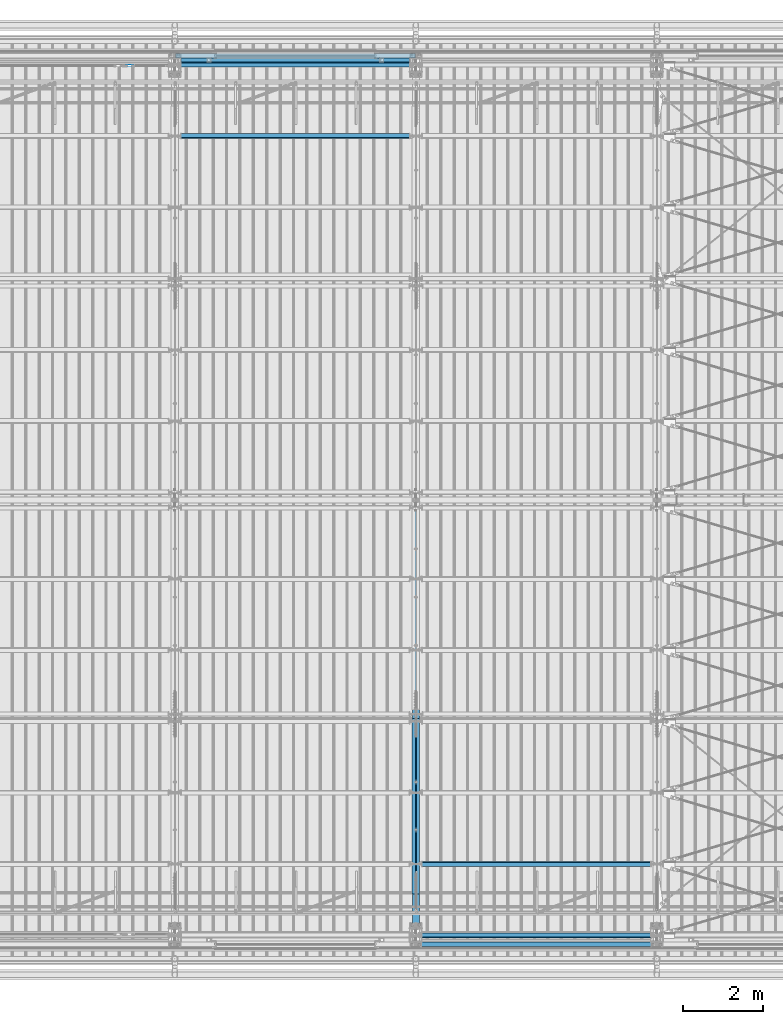
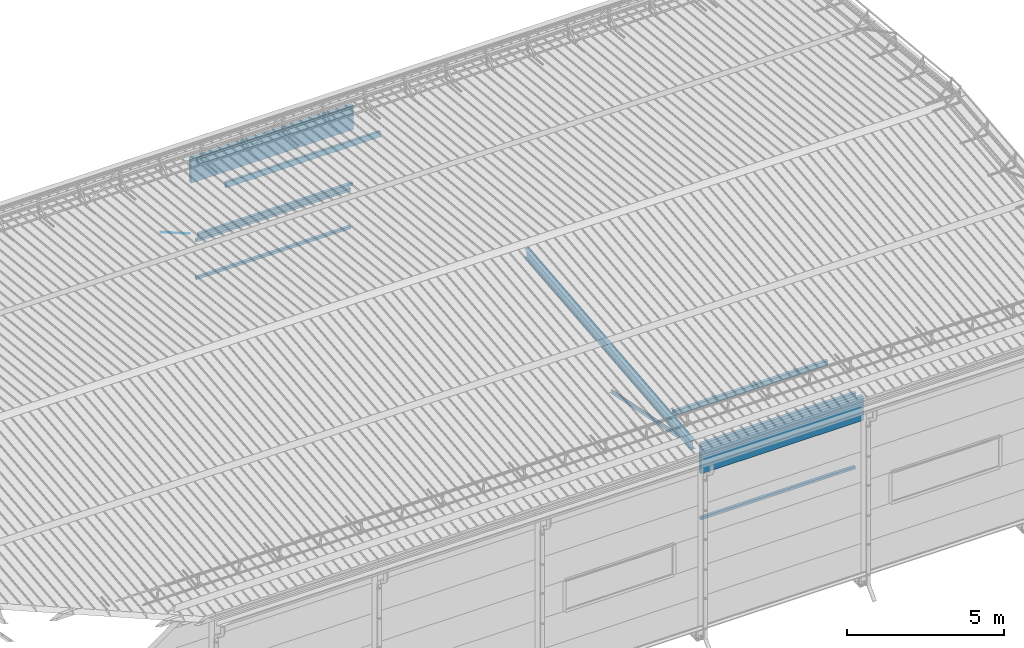
# One storey, part 271 of 709: 13 beams, 1 member, 1 opening, 14 elements without a shape of their own.
"""IFC4 building model written with IfcOpenShell, lengths in millimetres."""

from ifc_helpers import new_model, si_unit, direction, frame, origin_with_axes, place, context, subcontext, project, spatial, line, indexed_curve, outline, extrude, polygons, material, element, aggregate, save


model = new_model("IFC4")

# Units and contexts
model_context = context("Model", 3, precision=0.2, world=origin_with_axes(), true_north=direction((0.0, 1.0)))
body_context = subcontext(model_context, "Body", "Model", "MODEL_VIEW")
reference_context = subcontext(model_context, "Reference", "Model", "MODEL_VIEW")
ifc_project = project(units=[si_unit("LENGTHUNIT", "METRE", prefix="MILLI"), si_unit("AREAUNIT", "SQUARE_METRE"), si_unit("VOLUMEUNIT", "CUBIC_METRE"), si_unit("MASSUNIT", "GRAM", prefix="KILO"), si_unit("TIMEUNIT", "SECOND"), si_unit("PLANEANGLEUNIT", "RADIAN"), si_unit("SOLIDANGLEUNIT", "STERADIAN"), si_unit("THERMODYNAMICTEMPERATUREUNIT", "DEGREE_CELSIUS"), si_unit("LUMINOUSINTENSITYUNIT", "LUMEN")], contexts=[model_context])

# Site, building, storey
site_placement = place(None, origin_with_axes())
site = spatial("IfcSite", under=ifc_project, at=site_placement, CompositionType="ELEMENT")
building_placement = place(site_placement, origin_with_axes())
building = spatial("IfcBuilding", under=site, at=building_placement, Name="Undefined", CompositionType="ELEMENT")
storey_placement = place(building_placement, origin_with_axes())
storey = spatial("IfcBuildingStorey", under=building, at=storey_placement, Name="Undefined", CompositionType="ELEMENT", Elevation=0.0)

# Assembly, beam
assembly_1_placement = place(storey_placement, frame((34000.0, 346.0, 7089.70002), z_axis=(1.0, 0.0, 0.0), x_axis=(0.0, 0.9950371902, 0.099503719)))
assembly_1 = element("IfcElementAssembly", 1, at=assembly_1_placement, inside=storey)
ifc_material_1 = material(Name="C355-5", Category="STEEL")
beam_1_placement = place(assembly_1_placement, origin_with_axes())
beam_1 = element("IfcBeam", 2, at=beam_1_placement, material=ifc_material_1, ObjectType="432", context=body_context, shape_type="Tessellation", body=[
    polygons([(3.80474, -173.0, -87.0), (4.70474, -164.0, -87.0), (10665.6128, -164.0, -87.0), (10664.7128, -173.0, -87.0), (4.70474, -164.0, -3.0), (10665.6128, -164.0, -3.0), (37.50474, 164.0, -3.0), (10698.4128, 164.0, -3.0), (37.50474, 164.0, -87.0), (10698.4128, 164.0, -87.0), (38.40474, 173.0, -87.0), (10699.3128, 173.0, -87.0), (38.40474, 173.0, 87.0), (10699.3128, 173.0, 87.0), (37.50474, 164.0, 87.0), (10698.4128, 164.0, 87.0), (37.50474, 164.0, 3.0), (10698.4128, 164.0, 3.0), (4.70474, -164.0, 3.0), (10665.6128, -164.0, 3.0), (4.70474, -164.0, 87.0), (10665.6128, -164.0, 87.0), (3.80474, -173.0, 87.0), (10664.7128, -173.0, 87.0)], [[[1, 2, 3, 4]], [[2, 5, 6, 3]], [[5, 7, 8, 6]], [[7, 9, 10, 8]], [[9, 11, 12, 10]], [[11, 13, 14, 12]], [[13, 15, 16, 14]], [[15, 17, 18, 16]], [[17, 19, 20, 18]], [[19, 21, 22, 20]], [[21, 23, 24, 22]], [[23, 1, 4, 24]], [[6, 8, 10, 12, 14, 16, 18, 20, 22, 24, 4, 3]], [[23, 21, 19, 17, 15, 13, 11, 9, 7, 5, 2, 1]]], closed=True),
])
aggregate(assembly_1, [beam_1])

assembly_2_placement = place(storey_placement, frame((33949.0, 350.0596, 7109.99804), z_axis=(0.0, 0.1961161349, 0.9805806757), x_axis=(0.0, 0.9805806757, -0.1961161349)))
assembly_2 = element("IfcElementAssembly", 3, at=assembly_2_placement, inside=storey)
ifc_material_2 = material(Name="C345-5", Category="STEEL")
beam_2_placement = place(assembly_2_placement, origin_with_axes())
beam_2 = element("IfcBeam", 4, at=beam_2_placement, material=ifc_material_2, ObjectType="444", context=body_context, shape_type="Tessellation", body=[
    polygons([(868.11437, -45.0, -45.0), (868.11437, 45.0, -45.0), (5317.375, 45.0, -45.0), (5317.375, -45.0, -45.0), (868.11437, 45.0, -39.0), (5317.375, 45.0, -39.0), (868.11437, -39.0, -39.0), (5317.375, -39.0, -39.0), (868.11437, -39.0, 45.0), (5317.375, -39.0, 45.0), (868.11437, -45.0, 45.0), (5317.375, -45.0, 45.0)], [[[1, 2, 3, 4]], [[2, 5, 6, 3]], [[5, 7, 8, 6]], [[7, 9, 10, 8]], [[9, 11, 12, 10]], [[11, 1, 4, 12]], [[6, 8, 10, 12, 4, 3]], [[11, 9, 7, 5, 2, 1]]], closed=True),
])
aggregate(assembly_2, [beam_2])

assembly_3_placement = place(storey_placement, frame((34051.0, 5677.0596, 6044.59804), z_axis=(0.0, 0.1961161349, 0.9805806757), x_axis=(0.0, -0.9805806757, 0.1961161349)))
assembly_3 = element("IfcElementAssembly", 5, at=assembly_3_placement, inside=storey)
beam_3_placement = place(assembly_3_placement, origin_with_axes())
beam_3 = element("IfcBeam", 6, at=beam_3_placement, material=ifc_material_2, ObjectType="444", context=body_context, shape_type="Tessellation", body=[
    polygons([(115.12039, -45.0, -45.0), (115.12039, 45.0, -45.0), (4564.38102, 45.0, -45.0), (4564.38102, -45.0, -45.0), (115.12039, 45.0, -39.0), (4564.38102, 45.0, -39.0), (115.12039, -39.0, -39.0), (4564.38102, -39.0, -39.0), (115.12039, -39.0, 45.0), (4564.38102, -39.0, 45.0), (115.12039, -45.0, 45.0), (4564.38102, -45.0, 45.0)], [[[1, 2, 3, 4]], [[2, 5, 6, 3]], [[5, 7, 8, 6]], [[7, 9, 10, 8]], [[9, 11, 12, 10]], [[11, 1, 4, 12]], [[6, 8, 10, 12, 4, 3]], [[11, 9, 7, 5, 2, 1]]], closed=True),
])
aggregate(assembly_3, [beam_3])

assembly_4_placement = place(storey_placement, frame((34000.0, 173.0, 4310.0), z_axis=(0.0, 0.0, -1.0), x_axis=(1.0, 0.0, 0.0)))
assembly_4 = element("IfcElementAssembly", 7, at=assembly_4_placement, inside=storey)
ifc_material_3 = material(Name="C355", Category="STEEL")
beam_4_placement = place(assembly_4_placement, origin_with_axes())
beam_4 = element("IfcBeam", 8, at=beam_4_placement, material=ifc_material_3, ObjectType="546", context=body_context, shape_type="Tessellation", body=[
    polygons([(155.0, -47.0, -47.0), (155.0, -47.0, 47.0), (5845.0, -47.0, 47.0), (5845.0, -47.0, -47.0), (155.0, 47.0, 47.0), (5845.0, 47.0, 47.0), (155.0, 47.0, -47.0), (5845.0, 47.0, -47.0), (155.0, -50.0, -50.0), (155.0, 50.0, -50.0), (5845.0, 50.0, -50.0), (5845.0, -50.0, -50.0), (155.0, 50.0, 50.0), (5845.0, 50.0, 50.0), (155.0, -50.0, 50.0), (5845.0, -50.0, 50.0)], [[[1, 2, 3, 4]], [[2, 5, 6, 3]], [[5, 7, 8, 6]], [[7, 1, 4, 8]], [[9, 10, 11, 12]], [[10, 13, 14, 11]], [[13, 15, 16, 14]], [[15, 9, 12, 16]], [[14, 16, 12, 11], [6, 8, 4, 3]], [[15, 13, 10, 9], [7, 5, 2, 1]]], closed=True),
])
aggregate(assembly_4, [beam_4])

assembly_5_placement = place(storey_placement, frame((34000.0, 21950.0, 2550.0), z_axis=(0.0, 0.0, -1.0), x_axis=(-1.0, 0.0, 0.0)))
assembly_5 = element("IfcElementAssembly", 9, at=assembly_5_placement, inside=storey)
beam_5_placement = place(assembly_5_placement, origin_with_axes())
beam_5 = element("IfcBeam", 10, at=beam_5_placement, material=ifc_material_3, ObjectType="545", context=body_context, shape_type="Tessellation", body=[
    polygons([(155.0, -47.0, -47.0), (155.0, -47.0, 47.0), (5845.0, -47.0, 47.0), (5845.0, -47.0, -47.0), (155.0, 47.0, 47.0), (5845.0, 47.0, 47.0), (155.0, 47.0, -47.0), (5845.0, 47.0, -47.0), (155.0, -50.0, -50.0), (155.0, 50.0, -50.0), (5845.0, 50.0, -50.0), (5845.0, -50.0, -50.0), (155.0, 50.0, 50.0), (5845.0, 50.0, 50.0), (155.0, -50.0, 50.0), (5845.0, -50.0, 50.0)], [[[1, 2, 3, 4]], [[2, 5, 6, 3]], [[5, 7, 8, 6]], [[7, 1, 4, 8]], [[9, 10, 11, 12]], [[10, 13, 14, 11]], [[13, 15, 16, 14]], [[15, 9, 12, 16]], [[14, 16, 12, 11], [6, 8, 4, 3]], [[15, 13, 10, 9], [7, 5, 2, 1]]], closed=True),
])
aggregate(assembly_5, [beam_5])

assembly_6_placement = place(storey_placement, frame((34000.0, 21950.0, 4020.0), z_axis=(0.0, 0.0, -1.0), x_axis=(-1.0, 0.0, 0.0)))
assembly_6 = element("IfcElementAssembly", 11, at=assembly_6_placement, inside=storey)
beam_6_placement = place(assembly_6_placement, origin_with_axes())
beam_6 = element("IfcBeam", 12, at=beam_6_placement, material=ifc_material_3, ObjectType="545", context=body_context, shape_type="Tessellation", body=[
    polygons([(155.0, -47.0, -47.0), (155.0, -47.0, 47.0), (5845.0, -47.0, 47.0), (5845.0, -47.0, -47.0), (155.0, 47.0, 47.0), (5845.0, 47.0, 47.0), (155.0, 47.0, -47.0), (5845.0, 47.0, -47.0), (155.0, -50.0, -50.0), (155.0, 50.0, -50.0), (5845.0, 50.0, -50.0), (5845.0, -50.0, -50.0), (155.0, 50.0, 50.0), (5845.0, 50.0, 50.0), (155.0, -50.0, 50.0), (5845.0, -50.0, 50.0)], [[[1, 2, 3, 4]], [[2, 5, 6, 3]], [[5, 7, 8, 6]], [[7, 1, 4, 8]], [[9, 10, 11, 12]], [[10, 13, 14, 11]], [[13, 15, 16, 14]], [[15, 9, 12, 16]], [[14, 16, 12, 11], [6, 8, 4, 3]], [[15, 13, 10, 9], [7, 5, 2, 1]]], closed=True),
])
aggregate(assembly_6, [beam_6])

assembly_7_placement = place(storey_placement, frame((34000.0, 21827.0, 4310.0), z_axis=(0.0, 0.0, -1.0), x_axis=(-1.0, 0.0, 0.0)))
assembly_7 = element("IfcElementAssembly", 13, at=assembly_7_placement, inside=storey)
beam_7_placement = place(assembly_7_placement, origin_with_axes())
beam_7 = element("IfcBeam", 14, at=beam_7_placement, material=ifc_material_3, ObjectType="546", context=body_context, shape_type="Tessellation", body=[
    polygons([(155.0, -47.0, -47.0), (155.0, -47.0, 47.0), (5845.0, -47.0, 47.0), (5845.0, -47.0, -47.0), (155.0, 47.0, 47.0), (5845.0, 47.0, 47.0), (155.0, 47.0, -47.0), (5845.0, 47.0, -47.0), (155.0, -50.0, -50.0), (155.0, 50.0, -50.0), (5845.0, 50.0, -50.0), (5845.0, -50.0, -50.0), (155.0, 50.0, 50.0), (5845.0, 50.0, 50.0), (155.0, -50.0, 50.0), (5845.0, -50.0, 50.0)], [[[1, 2, 3, 4]], [[2, 5, 6, 3]], [[5, 7, 8, 6]], [[7, 1, 4, 8]], [[9, 10, 11, 12]], [[10, 13, 14, 11]], [[13, 15, 16, 14]], [[15, 9, 12, 16]], [[14, 16, 12, 11], [6, 8, 4, 3]], [[15, 13, 10, 9], [7, 5, 2, 1]]], closed=True),
])
aggregate(assembly_7, [beam_7])

# Assembly, member, voiding feature
assembly_8_placement = place(storey_placement, frame((27913.0, 21811.0, 4440.0), z_axis=(0.0, 1.0, 0.0), x_axis=(-0.9286065, 0.0, 0.371065989)))
assembly_8 = element("IfcElementAssembly", 15, at=assembly_8_placement, inside=storey)
member_placement = place(assembly_8_placement, origin_with_axes())
member = element("IfcMember", 16, at=member_placement, material=ifc_material_1, ObjectType="515", context=body_context, shape_type="Tessellation", body=[
    polygons([(1390.0, 7.36122, 4.25), (1390.0, 6.01041, 6.01041), (1390.0, 4.25, 7.36122), (1390.0, 2.19996, 8.21037), (1390.0, 0.0, 8.5), (1390.0, -2.19996, 8.21037), (1390.0, -4.25, 7.36122), (1390.0, -6.01041, 6.01041), (1390.0, -7.36122, 4.25), (1390.0, -8.21037, 2.19996), (1390.0, -8.5, 0.0), (1390.0, -8.21037, -2.19996), (1390.0, -7.36122, -4.25), (1390.0, -6.01041, -6.01041), (1390.0, -4.25, -7.36122), (1390.0, -2.19996, -8.21037), (1390.0, 0.0, -8.5), (1390.0, 2.19996, -8.21037), (1390.0, 4.25, -7.36122), (1390.0, 6.01041, -6.01041), (1390.0, 7.36122, -4.25), (1390.0, 8.21037, -2.19996), (1390.0, 8.5, 0.0), (1390.0, 8.21037, 2.19996), (1210.0, 8.21037, 2.19996), (1210.0, 7.36122, 4.25), (1210.0, 6.01041, 6.01041), (1210.0, 4.25, 7.36122), (1210.0, 2.19996, 8.21037), (1210.0, 0.0, 8.5), (1210.0, -2.19996, 8.21037), (1210.0, -4.25, 7.36122), (1210.0, -6.01041, 6.01041), (1210.0, -7.36122, 4.25), (1210.0, -8.21037, 2.19996), (1210.0, -8.5, 0.0), (1210.0, -8.21037, -2.19996), (1210.0, -7.36122, -4.25), (1210.0, -6.01041, -6.01041), (1210.0, -4.25, -7.36122), (1210.0, -2.19996, -8.21037), (1210.0, 0.0, -8.5), (1210.0, 2.19996, -8.21037), (1210.0, 4.25, -7.36122), (1210.0, 6.01041, -6.01041), (1210.0, 7.36122, -4.25), (1210.0, 8.21037, -2.19996), (1210.0, 8.5, 0.0), (1210.0, 10.0, 0.0), (1210.0, 9.65926, 2.58819), (1210.0, 8.66025, 5.0), (1210.0, 7.07107, 7.07107), (1210.0, 5.0, 8.66025), (1210.0, 2.58819, 9.65926), (1210.0, 0.0, 10.0), (1210.0, -2.58819, 9.65926), (1210.0, -5.0, 8.66025), (1210.0, -7.07107, 7.07107), (1210.0, -8.66025, 5.0), (1210.0, -9.65926, 2.58819), (1210.0, -10.0, 0.0), (1210.0, -9.65926, -2.58819), (1210.0, -8.66025, -5.0), (1210.0, -7.07107, -7.07107), (1210.0, -5.0, -8.66025), (1210.0, -2.58819, -9.65926), (1210.0, 0.0, -10.0), (1210.0, 2.58819, -9.65926), (1210.0, 5.0, -8.66025), (1210.0, 7.07107, -7.07107), (1210.0, 8.66025, -5.0), (1210.0, 9.65926, -2.58819), (70.0, 2.58819, 9.65926), (70.0, 5.0, 8.66025), (70.0, 7.07107, 7.07107), (70.0, 8.66025, 5.0), (70.0, 9.65926, 2.58819), (70.0, 10.0, 0.0), (70.0, 9.65926, -2.58819), (70.0, 8.66025, -5.0), (70.0, 7.07107, -7.07107), (70.0, 5.0, -8.66025), (70.0, 2.58819, -9.65926), (70.0, 0.0, -10.0), (70.0, -2.58819, -9.65926), (70.0, -5.0, -8.66025), (70.0, -7.07107, -7.07107), (70.0, -8.66025, -5.0), (70.0, -9.65926, -2.58819), (70.0, -10.0, 0.0), (70.0, -9.65926, 2.58819), (70.0, -8.66025, 5.0), (70.0, -7.07107, 7.07107), (70.0, -5.0, 8.66025), (70.0, -2.58819, 9.65926), (70.0, 0.0, 10.0)], [[[1, 2, 3, 4, 5, 6, 7, 8, 9, 10, 11, 12, 13, 14, 15, 16, 17, 18, 19, 20, 21, 22, 23, 24]], [[24, 25, 26, 1]], [[1, 26, 27, 2]], [[2, 27, 28, 3]], [[3, 28, 29, 4]], [[4, 29, 30, 5]], [[5, 30, 31, 6]], [[6, 31, 32, 7]], [[7, 32, 33, 8]], [[8, 33, 34, 9]], [[9, 34, 35, 10]], [[10, 35, 36, 11]], [[11, 36, 37, 12]], [[12, 37, 38, 13]], [[13, 38, 39, 14]], [[14, 39, 40, 15]], [[15, 40, 41, 16]], [[16, 41, 42, 17]], [[17, 42, 43, 18]], [[18, 43, 44, 19]], [[19, 44, 45, 20]], [[20, 45, 46, 21]], [[21, 46, 47, 22]], [[22, 47, 48, 23]], [[23, 48, 25, 24]], [[49, 50, 51, 52, 53, 54, 55, 56, 57, 58, 59, 60, 61, 62, 63, 64, 65, 66, 67, 68, 69, 70, 71, 72], [47, 46, 45, 44, 43, 42, 41, 40, 39, 38, 37, 36, 35, 34, 33, 32, 31, 30, 29, 28, 27, 26, 25, 48]], [[73, 74, 75, 76, 77, 78, 79, 80, 81, 82, 83, 84, 85, 86, 87, 88, 89, 90, 91, 92, 93, 94, 95, 96]], [[79, 78, 49, 72]], [[80, 79, 72, 71]], [[81, 80, 71, 70]], [[82, 81, 70, 69]], [[83, 82, 69, 68]], [[84, 83, 68, 67]], [[85, 84, 67, 66]], [[86, 85, 66, 65]], [[87, 86, 65, 64]], [[88, 87, 64, 63]], [[89, 88, 63, 62]], [[90, 89, 62, 61]], [[91, 90, 61, 60]], [[92, 91, 60, 59]], [[93, 92, 59, 58]], [[94, 93, 58, 57]], [[95, 94, 57, 56]], [[96, 95, 56, 55]], [[73, 96, 55, 54]], [[74, 73, 54, 53]], [[75, 74, 53, 52]], [[76, 75, 52, 51]], [[77, 76, 51, 50]], [[78, 77, 50, 49]]], closed=True),
])
voiding_feature_placement = place(member_placement, frame((1390.0, 0.0, 0.0), z_axis=(0.0, 1.0, 0.0), x_axis=(-1.0, 0.0, 0.0)))
element("IfcVoidingFeature", 17, at=voiding_feature_placement, cuts=member, PredefinedType="HOLE", context=reference_context, identifier="Reference", shape_type="SolidModel", body=[
    extrude(outline(indexed_curve([(10.5, 0.0), (10.14222, 2.7176), (9.09327, 5.25), (7.42462, 7.42462), (5.25, 9.09327), (2.7176, 10.14222), (0.0, 10.5), (-2.7176, 10.14222), (-5.25, 9.09327), (-7.42462, 7.42462), (-9.09327, 5.25), (-10.14222, 2.7176), (-10.5, 0.0), (-10.14222, -2.7176), (-9.09327, -5.25), (-7.42462, -7.42462), (-5.25, -9.09327), (-2.7176, -10.14222), (0.0, -10.5), (2.7176, -10.14222), (5.25, -9.09327), (7.42462, -7.42462), (9.09327, -5.25), (10.14222, -2.7176)], segments=[line(1, 2, 3, 4, 5, 6, 7, 8, 9, 10, 11, 12, 13, 14, 15, 16, 17, 18, 19, 20, 21, 22, 23, 24, 1)])), frame((0.0, 0.0, 0.0), z_axis=(-1.0, 0.0, 0.0), x_axis=(0.0, 0.0, 1.0)), (0.0, 0.0, -1.0), 180.0),
])
aggregate(assembly_8, [member])

# Assembly, beam
assembly_9_placement = place(storey_placement, frame((34000.0, 20063.34988, 7322.12913), z_axis=(0.0, -0.9950371902, 0.099503719), x_axis=(-1.0, 0.0, 0.0)))
assembly_9 = element("IfcElementAssembly", 18, at=assembly_9_placement, inside=storey)
beam_8_placement = place(assembly_9_placement, origin_with_axes())
beam_8 = element("IfcBeam", 19, at=beam_8_placement, material=ifc_material_3, ObjectType="579", context=body_context, shape_type="Tessellation", body=[
    polygons([(155.0, -96.0, -46.0), (155.0, -96.0, 46.0), (5845.0, -96.0, 46.0), (5845.0, -96.0, -46.0), (155.0, 96.0, 46.0), (5845.0, 96.0, 46.0), (155.0, 96.0, -46.0), (5845.0, 96.0, -46.0), (155.0, -100.0, -50.0), (155.0, 100.0, -50.0), (5845.0, 100.0, -50.0), (5845.0, -100.0, -50.0), (155.0, 100.0, 50.0), (5845.0, 100.0, 50.0), (155.0, -100.0, 50.0), (5845.0, -100.0, 50.0)], [[[1, 2, 3, 4]], [[2, 5, 6, 3]], [[5, 7, 8, 6]], [[7, 1, 4, 8]], [[9, 10, 11, 12]], [[10, 13, 14, 11]], [[13, 15, 16, 14]], [[15, 9, 12, 16]], [[14, 16, 12, 11], [6, 8, 4, 3]], [[15, 13, 10, 9], [7, 5, 2, 1]]], closed=True),
])
aggregate(assembly_9, [beam_8])

assembly_10_placement = place(storey_placement, frame((34000.0, 21841.04467, 7154.40952), z_axis=(0.0, -0.9950371902, 0.099503719), x_axis=(-1.0, 0.0, 0.0)))
assembly_10 = element("IfcElementAssembly", 20, at=assembly_10_placement, inside=storey)
beam_9_placement = place(assembly_10_placement, origin_with_axes())
beam_9 = element("IfcBeam", 21, at=beam_9_placement, material=ifc_material_3, ObjectType="578", context=body_context, shape_type="Tessellation", body=[
    polygons([(145.0, -86.0, -46.0), (145.0, -86.0, 46.0), (5855.0, -86.0, 46.0), (5855.0, -86.0, -46.0), (145.0, 86.0, 46.0), (5855.0, 86.0, 46.0), (145.0, 86.0, -46.0), (5855.0, 86.0, -46.0), (145.0, -90.0, -50.0), (145.0, 90.0, -50.0), (5855.0, 90.0, -50.0), (5855.0, -90.0, -50.0), (145.0, 90.0, 50.0), (5855.0, 90.0, 50.0), (145.0, -90.0, 50.0), (5855.0, -90.0, 50.0)], [[[1, 2, 3, 4]], [[2, 5, 6, 3]], [[5, 7, 8, 6]], [[7, 1, 4, 8]], [[9, 10, 11, 12]], [[10, 13, 14, 11]], [[13, 15, 16, 14]], [[15, 9, 12, 16]], [[14, 16, 12, 11], [6, 8, 4, 3]], [[15, 13, 10, 9], [7, 5, 2, 1]]], closed=True),
])
aggregate(assembly_10, [beam_9])

assembly_11_placement = place(storey_placement, frame((34000.0, 158.95533, 7154.40952), z_axis=(0.0, 0.9950371902, 0.099503719), x_axis=(1.0, 0.0, 0.0)))
assembly_11 = element("IfcElementAssembly", 22, at=assembly_11_placement, inside=storey)
beam_10_placement = place(assembly_11_placement, origin_with_axes())
beam_10 = element("IfcBeam", 23, at=beam_10_placement, material=ifc_material_3, ObjectType="578", context=body_context, shape_type="Tessellation", body=[
    polygons([(145.0, -86.0, -46.0), (145.0, -86.0, 46.0), (5855.0, -86.0, 46.0), (5855.0, -86.0, -46.0), (145.0, 86.0, 46.0), (5855.0, 86.0, 46.0), (145.0, 86.0, -46.0), (5855.0, 86.0, -46.0), (145.0, -90.0, -50.0), (145.0, 90.0, -50.0), (5855.0, 90.0, -50.0), (5855.0, -90.0, -50.0), (145.0, 90.0, 50.0), (5855.0, 90.0, 50.0), (145.0, -90.0, 50.0), (5855.0, -90.0, 50.0)], [[[1, 2, 3, 4]], [[2, 5, 6, 3]], [[5, 7, 8, 6]], [[7, 1, 4, 8]], [[9, 10, 11, 12]], [[10, 13, 14, 11]], [[13, 15, 16, 14]], [[15, 9, 12, 16]], [[14, 16, 12, 11], [6, 8, 4, 3]], [[15, 13, 10, 9], [7, 5, 2, 1]]], closed=True),
])
aggregate(assembly_11, [beam_10])

assembly_12_placement = place(storey_placement, frame((34000.0, 1936.65012, 7322.12913), z_axis=(0.0, 0.9950371902, 0.099503719), x_axis=(1.0, 0.0, 0.0)))
assembly_12 = element("IfcElementAssembly", 24, at=assembly_12_placement, inside=storey)
beam_11_placement = place(assembly_12_placement, origin_with_axes())
beam_11 = element("IfcBeam", 25, at=beam_11_placement, material=ifc_material_3, ObjectType="579", context=body_context, shape_type="Tessellation", body=[
    polygons([(155.0, -96.0, -46.0), (155.0, -96.0, 46.0), (5845.0, -96.0, 46.0), (5845.0, -96.0, -46.0), (155.0, 96.0, 46.0), (5845.0, 96.0, 46.0), (155.0, 96.0, -46.0), (5845.0, 96.0, -46.0), (155.0, -100.0, -50.0), (155.0, 100.0, -50.0), (5845.0, 100.0, -50.0), (5845.0, -100.0, -50.0), (155.0, 100.0, 50.0), (5845.0, 100.0, 50.0), (155.0, -100.0, 50.0), (5845.0, -100.0, 50.0)], [[[1, 2, 3, 4]], [[2, 5, 6, 3]], [[5, 7, 8, 6]], [[7, 1, 4, 8]], [[9, 10, 11, 12]], [[10, 13, 14, 11]], [[13, 15, 16, 14]], [[15, 9, 12, 16]], [[14, 16, 12, 11], [6, 8, 4, 3]], [[15, 13, 10, 9], [7, 5, 2, 1]]], closed=True),
])
aggregate(assembly_12, [beam_11])

assembly_13_placement = place(storey_placement, frame((34010.0, -60.0, 6845.0), z_axis=(0.0, 0.0, -1.0), x_axis=(1.0, 0.0, 0.0)))
assembly_13 = element("IfcElementAssembly", 26, at=assembly_13_placement, inside=storey)
ifc_material_4 = material(Name="Insulation", Category="Insulation")
beam_12_placement = place(assembly_13_placement, origin_with_axes())
beam_12 = element("IfcBeam", 27, at=beam_12_placement, material=ifc_material_4, ObjectType="P-108", context=body_context, shape_type="Tessellation", body=[
    polygons([(0.0, 60.0, 595.0), (0.0, -60.0, 595.0), (5980.0, -60.0, 595.0), (5980.0, 60.0, 595.0), (5980.0, 60.0, -351.923), (0.0, 60.0, -351.923), (0.0, -60.0, -351.923), (5980.0, -60.0, -351.923)], [[[1, 2, 3, 4]], [[1, 4, 5, 6]], [[2, 1, 6, 7]], [[3, 2, 7, 8]], [[4, 3, 8, 5]], [[7, 6, 5, 8]]], closed=True),
])
aggregate(assembly_13, [beam_12])

assembly_14_placement = place(storey_placement, frame((28010.0, 22060.0, 6845.0), z_axis=(0.0, 0.0, -1.0), x_axis=(1.0, 0.0, 0.0)))
assembly_14 = element("IfcElementAssembly", 28, at=assembly_14_placement, inside=storey)
beam_13_placement = place(assembly_14_placement, origin_with_axes())
beam_13 = element("IfcBeam", 29, at=beam_13_placement, material=ifc_material_4, ObjectType="P-108", context=body_context, shape_type="Tessellation", body=[
    polygons([(0.0, 60.0, 595.0), (0.0, -60.0, 595.0), (5980.0, -60.0, 595.0), (5980.0, 60.0, 595.0), (5980.0, 60.0, -351.923), (0.0, 60.0, -351.923), (0.0, -60.0, -351.923), (5980.0, -60.0, -351.923)], [[[1, 2, 3, 4]], [[1, 4, 5, 6]], [[2, 1, 6, 7]], [[3, 2, 7, 8]], [[4, 3, 8, 5]], [[7, 6, 5, 8]]], closed=True),
])
aggregate(assembly_14, [beam_13])

save(model, "model.ifc")
